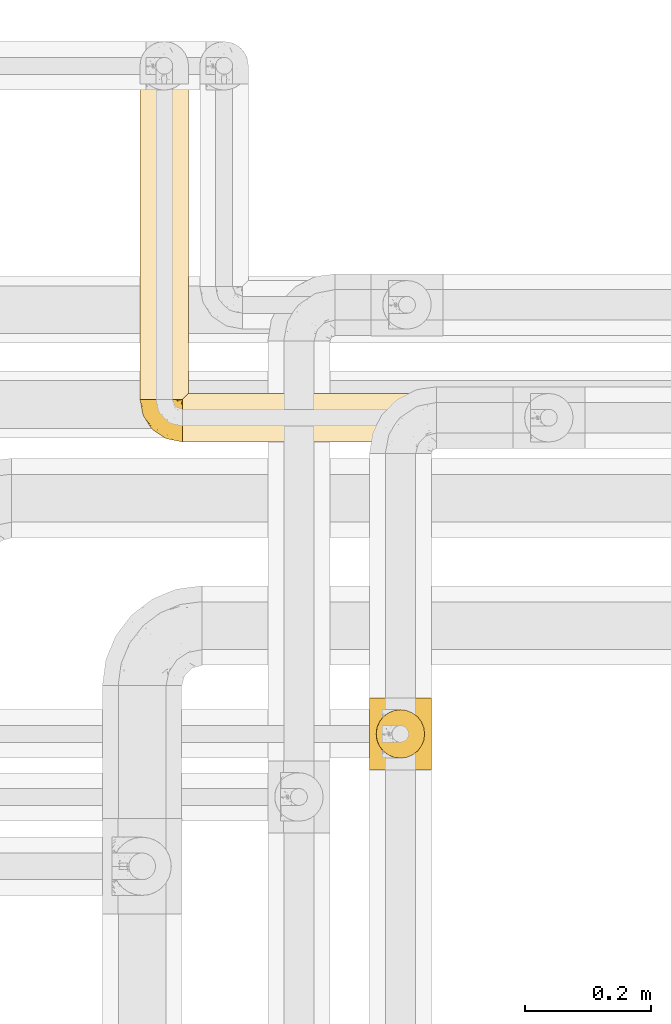
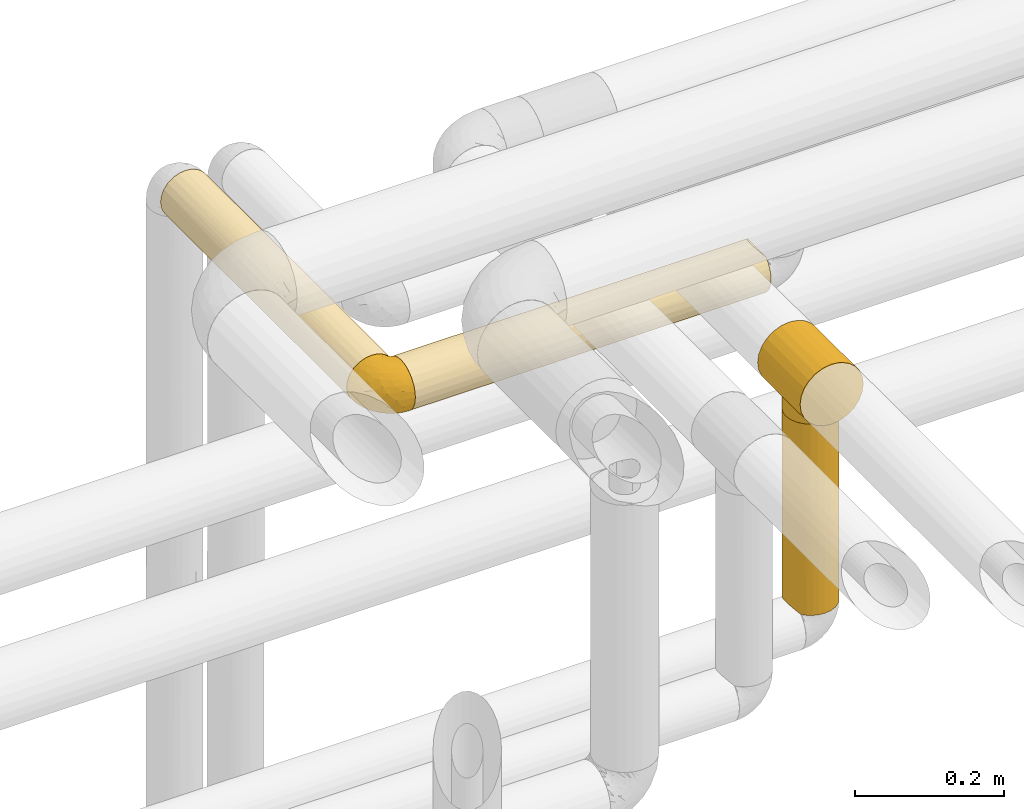
# One storey, part 364 of 827: 5 coverings.
"""IFC2X3 building model written with IfcOpenShell, lengths in millimetres."""

from ifc_helpers import new_model, entity, si_unit, converted_unit, derived_unit, direction, frame, origin, place, context, subcontext, project, spatial, faceted_brep, element, save


model = new_model("IFC2X3")

# Units and contexts
model_context = context("Model", 3, precision=0.01, world=origin(), true_north=direction((6.12303176911189e-17, 1.0)))
body_context = subcontext(model_context, "Body", "Model", "MODEL_VIEW")
ifc_project = project(units=[si_unit("LENGTHUNIT", "METRE", prefix="MILLI"), si_unit("AREAUNIT", "SQUARE_METRE"), si_unit("VOLUMEUNIT", "CUBIC_METRE"), converted_unit("PLANEANGLEUNIT", "DEGREE", entity("IfcRatioMeasure", 0.0174532925199433), si_unit("PLANEANGLEUNIT", "RADIAN"), dimensions=[0, 0, 0, 0, 0, 0, 0]), si_unit("MASSUNIT", "GRAM", prefix="KILO"), derived_unit("MASSDENSITYUNIT", [(si_unit("MASSUNIT", "GRAM", prefix="KILO"), 1), (si_unit("LENGTHUNIT", "METRE"), -3)]), derived_unit("MOMENTOFINERTIAUNIT", [(si_unit("LENGTHUNIT", "METRE"), 4)]), si_unit("TIMEUNIT", "SECOND"), si_unit("FREQUENCYUNIT", "HERTZ"), si_unit("THERMODYNAMICTEMPERATUREUNIT", "DEGREE_CELSIUS"), derived_unit("THERMALTRANSMITTANCEUNIT", [(si_unit("MASSUNIT", "GRAM", prefix="KILO"), 1), (si_unit("THERMODYNAMICTEMPERATUREUNIT", "KELVIN"), -1), (si_unit("TIMEUNIT", "SECOND"), -3)]), derived_unit("VOLUMETRICFLOWRATEUNIT", [(si_unit("LENGTHUNIT", "METRE"), 3), (si_unit("TIMEUNIT", "SECOND"), -1)]), derived_unit("MASSFLOWRATEUNIT", [(si_unit("MASSUNIT", "GRAM", prefix="KILO"), 1), (si_unit("TIMEUNIT", "SECOND"), -1)]), derived_unit("ROTATIONALFREQUENCYUNIT", [(si_unit("TIMEUNIT", "SECOND"), -1)]), si_unit("ELECTRICCURRENTUNIT", "AMPERE"), si_unit("ELECTRICVOLTAGEUNIT", "VOLT"), si_unit("POWERUNIT", "WATT"), si_unit("FORCEUNIT", "NEWTON", prefix="KILO"), si_unit("ILLUMINANCEUNIT", "LUX"), si_unit("LUMINOUSFLUXUNIT", "LUMEN"), si_unit("LUMINOUSINTENSITYUNIT", "CANDELA"), derived_unit("USERDEFINED", [(si_unit("MASSUNIT", "GRAM", prefix="KILO"), -1), (si_unit("LENGTHUNIT", "METRE"), -2), (si_unit("TIMEUNIT", "SECOND"), 3), (si_unit("LUMINOUSFLUXUNIT", "LUMEN"), 1)]), derived_unit("LINEARVELOCITYUNIT", [(si_unit("LENGTHUNIT", "METRE"), 1), (si_unit("TIMEUNIT", "SECOND"), -1)]), si_unit("PRESSUREUNIT", "PASCAL"), derived_unit("USERDEFINED", [(si_unit("LENGTHUNIT", "METRE"), -2), (si_unit("MASSUNIT", "GRAM", prefix="KILO"), 1), (si_unit("TIMEUNIT", "SECOND"), -2)]), derived_unit("LINEARFORCEUNIT", [(si_unit("MASSUNIT", "GRAM", prefix="KILO"), 1), (si_unit("LENGTHUNIT", "METRE"), 1), (si_unit("TIMEUNIT", "SECOND"), -2), (si_unit("LENGTHUNIT", "METRE"), -1)]), derived_unit("PLANARFORCEUNIT", [(si_unit("MASSUNIT", "GRAM", prefix="KILO"), 1), (si_unit("LENGTHUNIT", "METRE"), 1), (si_unit("TIMEUNIT", "SECOND"), -2), (si_unit("LENGTHUNIT", "METRE"), -2)])], contexts=[model_context])

# Site, building, storey
site_placement = place(None, origin())
site = spatial("IfcSite", under=ifc_project, at=site_placement, CompositionType="ELEMENT")
building_placement = place(site_placement, origin())
building = spatial("IfcBuilding", under=site, at=building_placement, CompositionType="ELEMENT")
storey_placement = place(building_placement, frame((0.0, 0.0, 28200.0)))
storey = spatial("IfcBuildingStorey", under=building, at=storey_placement, Name="08", CompositionType="ELEMENT", Elevation=28200.0)

# Coverings
covering_1_placement = place(storey_placement, frame((36215.03, 18963.91, 3160.0)))
element("IfcCovering", 1, at=covering_1_placement, inside=storey, Name=":ADSK_", ObjectType=":ADSK_", PredefinedType="INSULATION", context=body_context, shape_type="Brep", body=[
    faceted_brep([(20.8, 501.6, 73.25), (30.06, 501.6, 77.09), (40.0, 501.6, 78.4), (49.93, 501.6, 77.09), (59.2, 501.6, 73.25), (67.15, 501.6, 67.15), (73.25, 501.6, 59.2), (77.09, 501.6, 49.93), (78.4, 501.6, 40.0), (77.51, 501.6, 31.79), (74.9, 501.6, 23.98), (70.68, 501.6, 16.91), (65.05, 501.6, 10.9), (14.94, 501.6, 10.9), (9.31, 501.6, 16.91), (5.09, 501.6, 23.98), (2.48, 501.6, 31.79), (1.6, 501.6, 40.0), (2.9, 501.6, 49.93), (6.74, 501.6, 59.2), (12.84, 501.6, 67.15), (40.0, 1.6, 78.4), (30.06, 1.6, 77.09), (20.8, 1.6, 73.25), (12.84, 1.6, 67.15), (6.74, 1.6, 59.2), (2.9, 1.6, 49.93), (1.6, 1.6, 40.0), (2.9, 1.6, 30.06), (6.74, 1.6, 20.8), (12.84, 1.6, 12.84), (20.8, 1.6, 6.74), (30.06, 1.6, 2.9), (40.0, 1.6, 1.6), (48.2, 1.6, 2.48), (56.01, 1.6, 5.09), (63.08, 1.6, 9.31), (69.1, 1.6, 14.94), (69.1, 1.6, 65.05), (63.08, 1.6, 70.68), (56.01, 1.6, 74.9), (48.2, 1.6, 77.51), (77.02, 249.2, 29.81), (71.11, 243.29, 17.49), (73.07, 5.57, 20.48), (76.0, 8.5, 26.63), (74.63, 188.38, 23.41), (78.4, 227.27, 40.0), (77.79, 10.29, 33.21), (78.4, 10.9, 40.0), (50.18, 254.0, 2.97), (46.78, 492.91, 2.2), (53.36, 494.7, 4.0), (40.0, 275.93, 1.6), (62.51, 259.91, 8.88), (56.58, 314.82, 5.36), (40.0, 492.3, 1.6), (59.51, 497.63, 6.92), (29.81, 257.47, 2.97), (17.48, 247.3, 8.89), (23.43, 190.65, 5.35), (9.53, 230.73, 16.62), (33.21, 492.91, 2.2), (26.63, 494.7, 4.0), (20.48, 497.63, 6.92), (3.58, 261.19, 27.82), (1.6, 285.23, 40.0), (2.35, 293.81, 47.55), (4.52, 251.6, 54.69), (32.65, 290.19, 77.69), (25.3, 251.6, 75.47), (9.53, 251.6, 63.37), (16.62, 251.6, 70.46), (40.0, 217.97, 78.4), (52.17, 242.01, 76.41), (63.37, 272.47, 70.46), (77.02, 245.73, 50.18), (77.79, 10.29, 46.78), (74.64, 312.55, 56.56), (71.1, 255.89, 62.51), (76.0, 8.5, 53.36), (73.07, 5.57, 59.51)], [[[0, 1, 2, 3, 4, 5, 6, 7, 8, 9, 10, 11, 12, 13, 14, 15, 16, 17, 18, 19, 20]], [[21, 22, 23, 24, 25, 26, 27, 28, 29, 30, 31, 32, 33, 34, 35, 36, 37, 38, 39, 40, 41]], [[42, 10, 9]], [[10, 43, 11]], [[44, 37, 43]], [[42, 45, 46]], [[8, 47, 9]], [[43, 46, 44]], [[47, 42, 9]], [[47, 48, 42]], [[49, 48, 47]], [[50, 51, 52]], [[53, 50, 34]], [[43, 54, 12]], [[46, 10, 42]], [[50, 52, 55]], [[12, 11, 43]], [[55, 35, 50]], [[37, 36, 54]], [[35, 55, 54]], [[53, 56, 51]], [[35, 54, 36]], [[57, 12, 54]], [[42, 48, 45]], [[50, 35, 34]], [[53, 51, 50]], [[33, 53, 34]], [[55, 57, 54]], [[10, 46, 43]], [[57, 55, 52]], [[37, 54, 43]], [[44, 46, 45]], [[33, 58, 53]], [[58, 33, 32]], [[31, 59, 60]], [[59, 30, 61]], [[62, 58, 63]], [[62, 56, 53]], [[60, 63, 58]], [[64, 63, 60]], [[31, 30, 59]], [[59, 13, 64]], [[53, 58, 62]], [[61, 30, 29]], [[32, 60, 58]], [[29, 28, 65]], [[61, 14, 13]], [[64, 60, 59]], [[66, 17, 16]], [[65, 16, 15]], [[15, 61, 65]], [[66, 65, 28]], [[15, 14, 61]], [[66, 16, 65]], [[27, 66, 28]], [[65, 61, 29]], [[13, 59, 61]], [[32, 31, 60]], [[67, 26, 68]], [[22, 69, 70]], [[67, 17, 66, 27]], [[68, 26, 25]], [[67, 27, 26]], [[18, 68, 19]], [[68, 18, 67]], [[71, 20, 19]], [[71, 68, 25]], [[72, 71, 24]], [[2, 69, 73]], [[70, 23, 22]], [[22, 21, 73]], [[69, 1, 70]], [[2, 1, 69]], [[72, 0, 20]], [[70, 72, 23]], [[22, 73, 69]], [[70, 0, 72]], [[71, 72, 20]], [[24, 71, 25]], [[0, 70, 1]], [[23, 72, 24]], [[17, 67, 18]], [[68, 71, 19]], [[73, 41, 74]], [[40, 39, 75]], [[75, 74, 40]], [[47, 76, 77]], [[41, 73, 21]], [[74, 41, 40]], [[74, 4, 3]], [[75, 5, 4]], [[7, 6, 78]], [[79, 75, 38]], [[78, 80, 76]], [[79, 5, 75]], [[77, 76, 80]], [[6, 5, 79]], [[77, 49, 47]], [[78, 81, 80]], [[73, 74, 3]], [[78, 6, 79]], [[75, 39, 38]], [[8, 7, 76]], [[76, 47, 8]], [[74, 75, 4]], [[81, 78, 79]], [[81, 79, 38]], [[7, 78, 76]], [[2, 73, 3]], [[52, 51, 56, 62, 63, 64, 13, 12, 57]], [[37, 44, 45, 48, 49, 77, 80, 81, 38]]]),
])
covering_2_placement = place(storey_placement, frame((36282.53, 18896.41, 3160.0)))
element("IfcCovering", 2, at=covering_2_placement, inside=storey, Name=":ADSK_", ObjectType=":ADSK_", PredefinedType="INSULATION", context=body_context, shape_type="Brep", body=[
    faceted_brep([(1.6, 20.8, 6.74), (1.6, 12.84, 12.84), (1.6, 6.74, 20.8), (1.6, 2.9, 30.06), (1.6, 1.6, 40.0), (1.6, 2.9, 49.93), (1.6, 6.74, 59.2), (1.6, 12.84, 67.15), (1.6, 20.8, 73.25), (1.6, 30.06, 77.09), (1.6, 40.0, 78.4), (1.6, 48.2, 77.51), (1.6, 56.01, 74.9), (1.6, 63.08, 70.68), (1.6, 69.1, 65.05), (1.6, 69.1, 14.94), (1.6, 63.08, 9.31), (1.6, 56.01, 5.09), (1.6, 48.2, 2.48), (1.6, 40.0, 1.6), (1.6, 30.06, 2.9), (553.4, 2.9, 30.06), (553.4, 6.74, 20.8), (553.4, 12.84, 12.84), (553.4, 20.8, 6.74), (553.4, 30.06, 2.9), (553.4, 40.0, 1.6), (553.4, 49.93, 2.9), (553.4, 59.2, 6.74), (553.4, 67.15, 12.84), (553.4, 73.25, 20.8), (553.4, 77.09, 30.06), (553.4, 78.4, 40.0), (553.4, 77.51, 48.2), (553.4, 74.9, 56.01), (553.4, 70.68, 63.08), (553.4, 65.05, 69.1), (553.4, 14.94, 69.1), (553.4, 9.31, 63.08), (553.4, 5.09, 56.01), (553.4, 2.48, 48.2), (553.4, 1.6, 40.0), (268.81, 52.17, 3.58), (272.56, 77.02, 29.8), (227.27, 78.4, 40.0), (10.29, 77.79, 33.21), (10.9, 78.4, 40.0), (357.32, 74.63, 23.42), (281.58, 71.09, 17.46), (296.41, 63.37, 9.53), (8.5, 76.0, 26.63), (5.57, 73.07, 20.48), (217.97, 40.0, 1.6), (209.63, 32.43, 2.35), (253.62, 25.3, 4.52), (215.59, 2.33, 32.5), (277.5, 4.52, 25.3), (277.5, 16.62, 9.53), (253.62, 9.53, 16.62), (277.5, 1.6, 40.0), (337.02, 1.6, 40.0), (286.18, 3.58, 52.17), (258.58, 9.53, 63.37), (327.72, 40.0, 78.4), (282.43, 29.8, 77.02), (544.7, 33.21, 77.79), (197.67, 23.42, 74.63), (273.41, 17.46, 71.09), (546.5, 26.63, 76.0), (544.1, 40.0, 78.4), (549.42, 20.48, 73.07), (279.27, 50.19, 77.02), (284.96, 62.52, 71.09), (549.42, 59.51, 73.07), (270.03, 71.09, 62.52), (359.39, 56.59, 74.63), (544.7, 46.78, 77.79), (275.72, 77.02, 50.19), (10.29, 77.79, 46.78), (8.5, 76.0, 53.36), (195.6, 74.63, 56.59), (546.5, 53.36, 76.0), (5.57, 73.07, 59.51)], [[[0, 1, 2, 3, 4, 5, 6, 7, 8, 9, 10, 11, 12, 13, 14, 15, 16, 17, 18, 19, 20]], [[21, 22, 23, 24, 25, 26, 27, 28, 29, 30, 31, 32, 33, 34, 35, 36, 37, 38, 39, 40, 41]], [[42, 18, 17]], [[32, 43, 44]], [[43, 32, 31]], [[45, 46, 44]], [[31, 30, 47]], [[30, 48, 47]], [[48, 29, 49]], [[45, 43, 50]], [[44, 43, 45]], [[47, 50, 43]], [[51, 50, 47]], [[30, 29, 48]], [[48, 15, 51]], [[26, 52, 27]], [[49, 29, 28]], [[28, 27, 42]], [[52, 19, 18]], [[42, 49, 28]], [[17, 49, 42]], [[51, 47, 48]], [[17, 16, 49]], [[52, 18, 42]], [[49, 16, 15]], [[31, 47, 43]], [[15, 48, 49]], [[52, 42, 27]], [[53, 25, 54]], [[21, 55, 56]], [[53, 19, 52, 26]], [[54, 57, 0]], [[57, 54, 24]], [[53, 26, 25]], [[23, 57, 24]], [[57, 1, 0]], [[0, 20, 54]], [[22, 56, 58]], [[4, 55, 59]], [[56, 22, 21]], [[56, 2, 58]], [[23, 58, 57]], [[21, 41, 60, 59]], [[1, 57, 58]], [[22, 58, 23]], [[53, 54, 20]], [[2, 1, 58]], [[56, 55, 3]], [[2, 56, 3]], [[24, 54, 25]], [[59, 55, 21]], [[19, 53, 20]], [[55, 4, 3]], [[60, 40, 61]], [[39, 38, 62]], [[62, 61, 39]], [[63, 64, 65]], [[40, 60, 41]], [[61, 40, 39]], [[61, 6, 5]], [[62, 7, 6]], [[9, 8, 66]], [[67, 62, 37]], [[66, 68, 64]], [[67, 7, 62]], [[65, 64, 68]], [[8, 7, 67]], [[65, 69, 63]], [[66, 70, 68]], [[60, 61, 5]], [[66, 8, 67]], [[62, 38, 37]], [[10, 9, 64]], [[64, 63, 10]], [[61, 62, 6]], [[70, 66, 67]], [[70, 67, 37]], [[9, 66, 64]], [[5, 4, 59, 60]], [[71, 12, 11]], [[12, 72, 13]], [[73, 36, 72]], [[34, 74, 35]], [[10, 63, 11]], [[72, 75, 73]], [[63, 76, 71]], [[69, 76, 63]], [[77, 78, 79]], [[77, 79, 80]], [[63, 71, 11]], [[75, 12, 71]], [[71, 81, 75]], [[14, 13, 72]], [[80, 34, 77]], [[36, 35, 74]], [[82, 80, 79]], [[34, 80, 74]], [[44, 46, 78]], [[72, 74, 14]], [[82, 14, 74]], [[71, 76, 81]], [[77, 34, 33]], [[44, 78, 77]], [[32, 44, 33]], [[80, 82, 74]], [[73, 75, 81]], [[12, 75, 72]], [[36, 74, 72]], [[44, 77, 33]], [[14, 82, 79, 78, 46, 45, 50, 51, 15]], [[69, 65, 68, 70, 37, 36, 73, 81, 76]]]),
])
covering_3_placement = place(storey_placement, frame((36214.98, 18896.36, 3159.95)))
element("IfcCovering", 3, at=covering_3_placement, inside=storey, Name=":ADSK_", ObjectType=":ADSK_", PredefinedType="INSULATION", context=body_context, shape_type="Brep", body=[
    faceted_brep([(69.15, 23.36, 74.68), (69.15, 16.07, 70.1), (69.15, 9.98, 64.01), (69.15, 5.4, 56.72), (69.15, 2.56, 48.6), (69.15, 1.6, 40.05), (69.15, 2.56, 31.49), (69.15, 5.41, 23.36), (69.15, 9.99, 16.07), (69.15, 16.08, 9.98), (69.15, 23.37, 5.4), (69.15, 31.49, 2.56), (69.15, 40.05, 1.6), (69.15, 48.15, 2.46), (69.15, 55.88, 5.01), (69.15, 62.9, 9.13), (69.15, 68.89, 14.62), (69.15, 68.89, 16.82), (69.15, 68.89, 18.56), (69.15, 68.89, 20.52), (69.15, 68.89, 22.49), (69.15, 68.89, 24.46), (69.15, 68.89, 26.42), (69.15, 68.89, 28.39), (69.15, 68.89, 30.36), (69.15, 68.89, 32.55), (69.15, 68.89, 34.75), (69.15, 68.89, 36.94), (69.15, 68.89, 39.13), (69.15, 68.89, 41.33), (69.15, 68.89, 43.52), (69.15, 68.89, 45.72), (69.15, 68.89, 47.91), (69.15, 68.89, 50.11), (69.15, 68.89, 52.3), (69.15, 68.89, 54.49), (69.15, 68.89, 56.69), (69.15, 68.89, 58.88), (69.15, 68.89, 61.08), (69.15, 68.89, 63.27), (69.15, 68.89, 65.47), (69.15, 62.89, 70.97), (69.15, 55.86, 75.09), (69.15, 48.13, 77.64), (69.15, 40.05, 78.5), (69.15, 31.49, 77.53), (68.89, 69.15, 14.62), (62.89, 69.15, 9.12), (55.87, 69.15, 5.0), (48.14, 69.15, 2.46), (40.05, 69.15, 1.6), (30.09, 69.15, 2.91), (20.82, 69.15, 6.75), (12.86, 69.15, 12.86), (6.75, 69.15, 20.82), (2.91, 69.15, 30.09), (1.6, 69.15, 40.05), (2.91, 69.15, 50.0), (6.75, 69.15, 59.27), (12.86, 69.15, 67.23), (20.82, 69.15, 73.34), (30.09, 69.15, 77.19), (40.05, 69.15, 78.5), (48.14, 69.15, 77.63), (55.87, 69.15, 75.09), (62.89, 69.15, 70.97), (68.89, 69.15, 65.47), (68.89, 69.15, 63.27), (68.89, 69.15, 62.29), (68.89, 69.15, 60.7), (68.89, 69.15, 59.11), (68.89, 69.15, 57.52), (68.89, 69.15, 55.93), (68.89, 69.15, 54.34), (68.89, 69.15, 52.76), (68.89, 69.15, 51.17), (68.89, 69.15, 49.58), (68.89, 69.15, 47.99), (68.89, 69.15, 46.4), (68.89, 69.15, 44.81), (68.89, 69.15, 43.22), (68.89, 69.15, 41.63), (68.89, 69.15, 40.05), (68.89, 69.15, 38.46), (68.89, 69.15, 36.87), (68.89, 69.15, 35.28), (68.89, 69.15, 33.69), (68.89, 69.15, 32.1), (68.89, 69.15, 30.51), (68.89, 69.15, 28.92), (68.89, 69.15, 27.33), (68.89, 69.15, 25.37), (68.89, 69.15, 23.4), (68.89, 69.15, 21.21), (68.89, 69.15, 19.01), (68.89, 69.15, 16.82), (68.97, 68.96, 42.32), (68.96, 68.97, 44.02), (68.97, 68.97, 47.13), (68.97, 68.97, 48.74), (68.98, 68.95, 23.57), (68.97, 68.96, 25.13), (68.96, 68.98, 61.34), (68.96, 68.97, 22.02), (68.96, 68.97, 29.72), (68.96, 68.98, 56.73), (68.96, 68.97, 55.14), (68.96, 68.97, 37.66), (69.0, 68.94, 64.12), (68.96, 68.98, 28.13), (68.96, 68.98, 26.62), (68.97, 68.96, 31.46), (68.96, 68.97, 16.16), (68.96, 68.98, 39.16), (68.96, 68.98, 50.37), (68.97, 68.97, 17.69), (68.97, 68.96, 19.17), (68.97, 68.97, 62.78), (68.96, 68.97, 58.35), (68.96, 68.98, 45.53), (68.97, 68.96, 59.91), (68.97, 68.97, 65.47), (69.02, 68.94, 65.47), (69.08, 68.92, 65.47), (68.97, 68.97, 14.62), (68.94, 69.02, 14.62), (68.92, 69.08, 14.62), (68.96, 68.98, 20.59), (68.96, 68.97, 32.99), (68.95, 68.98, 34.48), (68.96, 68.97, 51.91), (68.92, 69.08, 65.47), (68.94, 69.02, 65.47), (68.98, 68.96, 53.48), (69.08, 68.92, 14.62), (69.02, 68.94, 14.62), (68.96, 68.97, 40.77), (68.97, 68.96, 35.97), (61.33, 67.02, 7.84), (53.1, 63.33, 3.53), (63.33, 64.61, 8.32), (49.27, 49.27, 1.6), (55.53, 51.4, 2.19), (54.6, 43.94, 1.6), (41.99, 61.87, 1.6), (57.07, 61.54, 4.57), (57.95, 57.95, 3.96), (51.56, 56.12, 2.28), (41.58, 63.4, 1.6), (61.7, 65.41, 7.69), (63.33, 53.1, 3.53), (65.0, 63.04, 8.32), (67.02, 61.33, 7.84), (61.87, 41.99, 1.6), (43.94, 54.6, 1.6), (61.21, 56.6, 4.34), (63.4, 41.58, 1.6), (33.11, 13.72, 29.63), (52.82, 5.82, 27.34), (43.3, 6.74, 40.05), (33.73, 58.82, 2.39), (36.52, 51.58, 2.43), (24.87, 42.09, 9.07), (14.17, 46.12, 16.64), (18.43, 55.56, 9.54), (28.67, 52.38, 4.52), (26.0, 61.54, 4.52), (49.25, 23.76, 7.49), (59.72, 20.5, 7.49), (55.1, 14.64, 12.85), (44.72, 41.77, 2.35), (34.15, 16.28, 22.66), (5.25, 49.4, 32.9), (6.75, 52.34, 25.33), (55.54, 4.3, 40.05), (10.47, 58.67, 16.64), (25.49, 25.26, 19.99), (35.53, 20.17, 16.37), (48.22, 34.7, 3.26), (58.71, 28.67, 3.75), (57.42, 8.62, 19.58), (34.84, 33.37, 7.5), (36.87, 41.35, 4.04), (45.01, 17.15, 13.94), (44.4, 12.68, 19.58), (23.96, 21.47, 28.21), (11.2, 41.11, 24.75), (10.56, 37.53, 31.42), (16.81, 30.64, 26.2), (17.38, 26.66, 33.36), (21.38, 21.38, 40.05), (32.34, 14.06, 40.05), (4.3, 55.54, 40.05), (20.65, 35.17, 16.14), (29.66, 29.04, 12.85), (39.6, 24.34, 10.47), (42.55, 29.33, 6.49), (6.74, 43.3, 40.05), (14.06, 32.34, 40.05), (26.84, 57.75, 75.57), (5.28, 49.41, 47.37), (18.52, 27.85, 52.91), (33.13, 13.7, 50.46), (55.1, 14.63, 67.23), (57.43, 8.61, 60.5), (20.72, 48.85, 70.55), (11.46, 54.13, 63.45), (17.69, 37.84, 62.61), (49.26, 23.75, 72.6), (59.73, 20.49, 72.6), (58.71, 28.66, 76.34), (29.72, 20.83, 59.34), (35.35, 55.15, 77.76), (43.94, 54.6, 78.5), (41.99, 61.87, 78.5), (63.4, 41.58, 78.5), (4.93, 57.58, 53.16), (17.46, 59.91, 70.55), (10.94, 36.94, 48.88), (8.92, 45.72, 54.76), (52.83, 5.82, 52.74), (29.34, 37.91, 71.93), (30.26, 50.18, 75.79), (44.4, 12.67, 60.5), (39.06, 49.29, 77.86), (43.06, 42.64, 77.64), (54.6, 43.94, 78.5), (49.27, 49.27, 78.5), (42.69, 19.45, 67.23), (48.2, 34.7, 76.82), (61.87, 41.99, 78.5), (33.44, 62.29, 77.8), (29.67, 29.01, 67.23), (38.5, 31.47, 73.2), (23.35, 37.18, 67.66), (34.97, 43.45, 75.99), (53.1, 63.33, 76.57), (59.68, 67.23, 73.21), (62.19, 66.07, 71.93), (64.11, 65.22, 71.07), (57.97, 61.99, 75.09), (57.95, 57.95, 76.13), (63.33, 53.09, 76.57), (51.77, 56.84, 77.69), (67.02, 61.33, 72.26), (64.98, 63.06, 71.77), (55.53, 51.41, 77.9), (61.22, 56.61, 75.75)], [[[0, 1, 2, 3, 4, 5, 6, 7, 8, 9, 10, 11, 12, 13, 14, 15, 16, 17, 18, 19, 20, 21, 22, 23, 24, 25, 26, 27, 28, 29, 30, 31, 32, 33, 34, 35, 36, 37, 38, 39, 40, 41, 42, 43, 44, 45]], [[46, 47, 48, 49, 50, 51, 52, 53, 54, 55, 56, 57, 58, 59, 60, 61, 62, 63, 64, 65, 66, 67, 68, 69, 70, 71, 72, 73, 74, 75, 76, 77, 78, 79, 80, 81, 82, 83, 84, 85, 86, 87, 88, 89, 90, 91, 92, 93, 94, 95]], [[96, 97, 30]], [[98, 77, 99]], [[100, 101, 21]], [[69, 68, 102]], [[20, 19, 103]], [[24, 23, 104]], [[20, 103, 100]], [[72, 105, 106]], [[84, 83, 107]], [[89, 88, 104]], [[108, 67, 66]], [[109, 110, 90]], [[111, 25, 24]], [[112, 17, 16]], [[82, 113, 83]], [[109, 23, 22]], [[114, 76, 75]], [[105, 36, 106]], [[104, 111, 24]], [[18, 115, 116]], [[97, 96, 80]], [[67, 108, 117]], [[105, 71, 118]], [[31, 97, 119]], [[102, 120, 69]], [[108, 121, 122, 123, 40]], [[112, 95, 115]], [[17, 115, 18]], [[94, 116, 115]], [[117, 68, 67]], [[38, 117, 39]], [[112, 124, 125, 126, 46]], [[17, 112, 115]], [[70, 120, 118]], [[39, 117, 108]], [[120, 38, 37]], [[120, 37, 118]], [[120, 70, 69]], [[116, 94, 127]], [[128, 86, 129]], [[117, 38, 102]], [[74, 130, 75]], [[99, 33, 32]], [[115, 95, 94]], [[39, 108, 40]], [[108, 66, 131, 132, 121]], [[105, 72, 71]], [[118, 37, 36]], [[71, 70, 118]], [[35, 106, 36]], [[36, 105, 118]], [[35, 133, 106]], [[74, 73, 133]], [[106, 133, 73]], [[99, 114, 33]], [[133, 35, 34]], [[73, 72, 106]], [[95, 112, 46]], [[112, 16, 134, 135, 124]], [[130, 114, 75]], [[99, 76, 114]], [[114, 130, 33]], [[34, 33, 130]], [[78, 77, 98]], [[98, 119, 78]], [[130, 133, 34]], [[133, 130, 74]], [[79, 97, 80]], [[98, 99, 32]], [[98, 32, 31]], [[77, 76, 99]], [[97, 79, 119]], [[136, 96, 29]], [[30, 97, 31]], [[136, 29, 28]], [[81, 80, 96]], [[29, 96, 30]], [[31, 119, 98]], [[119, 79, 78]], [[96, 136, 81]], [[82, 81, 136]], [[113, 107, 83]], [[84, 107, 137]], [[107, 27, 137]], [[113, 28, 107]], [[27, 107, 28]], [[85, 84, 137]], [[137, 27, 26]], [[113, 136, 28]], [[136, 113, 82]], [[109, 89, 104]], [[86, 85, 129]], [[89, 109, 90]], [[111, 87, 128]], [[26, 129, 137]], [[88, 111, 104]], [[25, 111, 128]], [[22, 110, 109]], [[23, 109, 104]], [[110, 91, 90]], [[100, 92, 101]], [[110, 22, 101]], [[91, 110, 101]], [[116, 19, 18]], [[111, 88, 87]], [[127, 103, 19]], [[25, 128, 26]], [[86, 128, 87]], [[128, 129, 26]], [[137, 129, 85]], [[120, 102, 38]], [[117, 102, 68]], [[91, 101, 92]], [[21, 101, 22]], [[93, 92, 103]], [[100, 21, 20]], [[100, 103, 92]], [[127, 93, 103]], [[93, 127, 94]], [[116, 127, 19]], [[126, 138, 47]], [[48, 138, 139]], [[140, 125, 124]], [[141, 142, 143]], [[144, 49, 139]], [[145, 140, 146]], [[48, 139, 49]], [[139, 145, 147]], [[49, 144, 148, 50]], [[126, 125, 149]], [[14, 13, 150]], [[151, 146, 140]], [[149, 140, 145]], [[152, 151, 135]], [[152, 14, 150]], [[16, 15, 134]], [[13, 153, 150]], [[124, 151, 140]], [[141, 147, 142]], [[14, 152, 15]], [[15, 152, 134]], [[47, 46, 126]], [[139, 154, 144]], [[138, 48, 47]], [[125, 140, 149]], [[135, 134, 152]], [[146, 155, 142]], [[145, 146, 147]], [[149, 139, 138]], [[147, 141, 154]], [[147, 146, 142]], [[139, 147, 154]], [[139, 149, 145]], [[149, 138, 126]], [[155, 146, 151]], [[150, 143, 142]], [[152, 155, 151]], [[150, 142, 155]], [[13, 12, 156, 153]], [[153, 143, 150]], [[152, 150, 155]], [[151, 124, 135]], [[157, 158, 159]], [[160, 154, 161]], [[162, 163, 164]], [[165, 166, 160]], [[167, 168, 169]], [[141, 170, 161]], [[156, 12, 11]], [[158, 157, 171]], [[172, 55, 173]], [[158, 6, 174]], [[175, 54, 53]], [[52, 166, 164]], [[52, 164, 53]], [[54, 175, 173]], [[166, 52, 51]], [[176, 177, 171]], [[178, 143, 179]], [[156, 11, 179]], [[8, 7, 180]], [[169, 9, 8]], [[179, 143, 153, 156]], [[179, 11, 10]], [[168, 179, 10]], [[181, 162, 182]], [[179, 167, 178]], [[183, 184, 177]], [[183, 169, 184]], [[176, 171, 185]], [[172, 186, 187]], [[158, 7, 6]], [[159, 158, 174]], [[184, 180, 158]], [[54, 173, 55]], [[180, 169, 8]], [[188, 189, 187]], [[9, 168, 10]], [[186, 188, 187]], [[190, 157, 159, 191]], [[55, 172, 192]], [[176, 193, 194]], [[161, 170, 182]], [[162, 164, 165]], [[175, 164, 163]], [[51, 50, 148]], [[167, 195, 196]], [[178, 182, 170]], [[6, 5, 174]], [[158, 180, 7]], [[169, 180, 184]], [[169, 168, 9]], [[179, 168, 167]], [[182, 162, 165]], [[162, 194, 193]], [[161, 165, 160]], [[195, 181, 196]], [[192, 172, 197]], [[192, 56, 55]], [[189, 190, 198]], [[198, 197, 187]], [[172, 187, 197]], [[185, 189, 188]], [[198, 187, 189]], [[186, 172, 173]], [[173, 163, 186]], [[193, 186, 163]], [[176, 185, 188]], [[185, 157, 190]], [[188, 186, 193]], [[177, 176, 194]], [[188, 193, 176]], [[162, 193, 163]], [[195, 177, 194]], [[171, 177, 184]], [[181, 195, 194]], [[183, 167, 169]], [[162, 181, 194]], [[196, 182, 178]], [[158, 171, 184]], [[171, 157, 185]], [[177, 195, 183]], [[167, 183, 195]], [[182, 196, 181]], [[178, 170, 143]], [[178, 167, 196]], [[164, 175, 53]], [[173, 175, 163]], [[160, 51, 148]], [[164, 166, 165]], [[51, 160, 166]], [[160, 148, 144, 154]], [[141, 161, 154]], [[182, 165, 161]], [[190, 189, 185]], [[143, 170, 141]], [[60, 199, 61]], [[197, 200, 192]], [[201, 190, 202]], [[200, 57, 192]], [[203, 204, 2]], [[205, 206, 207]], [[208, 209, 210]], [[211, 207, 201]], [[212, 213, 214]], [[45, 215, 210]], [[216, 206, 58]], [[45, 44, 215]], [[59, 217, 60]], [[60, 217, 199]], [[0, 45, 210]], [[218, 201, 219]], [[202, 159, 220]], [[205, 221, 222]], [[223, 204, 203]], [[1, 203, 2]], [[57, 200, 216]], [[220, 3, 204]], [[220, 174, 4]], [[1, 0, 209]], [[212, 224, 213]], [[225, 226, 227]], [[228, 223, 203]], [[208, 210, 229]], [[210, 226, 229]], [[3, 220, 4]], [[58, 206, 59]], [[209, 203, 1]], [[202, 220, 223]], [[228, 203, 208]], [[202, 211, 201]], [[3, 2, 204]], [[202, 190, 191, 159]], [[210, 215, 230, 226]], [[199, 212, 231]], [[232, 233, 221]], [[233, 208, 229]], [[207, 206, 219]], [[217, 206, 205]], [[227, 224, 225]], [[233, 232, 228]], [[201, 207, 219]], [[234, 232, 221]], [[218, 219, 200]], [[202, 223, 211]], [[174, 220, 159]], [[174, 5, 4]], [[61, 231, 62]], [[220, 204, 223]], [[210, 209, 0]], [[203, 209, 208]], [[225, 233, 229]], [[224, 227, 213]], [[221, 233, 235]], [[57, 56, 192]], [[198, 218, 197]], [[200, 219, 216]], [[201, 198, 190]], [[197, 218, 200]], [[198, 201, 218]], [[206, 216, 219]], [[58, 57, 216]], [[231, 212, 214]], [[222, 212, 199]], [[228, 211, 223]], [[207, 211, 232]], [[62, 231, 214]], [[199, 231, 61]], [[233, 228, 208]], [[211, 228, 232]], [[222, 221, 235]], [[234, 205, 207]], [[206, 217, 59]], [[199, 217, 205]], [[205, 222, 199]], [[224, 222, 235]], [[222, 224, 212]], [[224, 235, 225]], [[233, 225, 235]], [[226, 225, 229]], [[205, 234, 221]], [[207, 232, 234]], [[63, 214, 236]], [[214, 213, 236]], [[214, 63, 62]], [[237, 236, 238]], [[238, 132, 131]], [[236, 237, 64]], [[239, 240, 241]], [[63, 236, 64]], [[131, 66, 65]], [[237, 131, 65]], [[242, 230, 43]], [[237, 65, 64]], [[239, 121, 132]], [[42, 242, 43]], [[241, 240, 243]], [[41, 123, 244]], [[43, 230, 215, 44]], [[244, 122, 245]], [[227, 246, 243]], [[241, 247, 245]], [[121, 239, 245]], [[41, 40, 123]], [[132, 238, 239]], [[244, 42, 41]], [[131, 237, 238]], [[240, 239, 238]], [[245, 239, 241]], [[247, 241, 246]], [[247, 244, 245]], [[238, 236, 240]], [[243, 236, 213]], [[236, 243, 240]], [[227, 226, 246]], [[243, 213, 227]], [[242, 246, 226]], [[243, 246, 241]], [[246, 242, 247]], [[244, 247, 242]], [[242, 226, 230]], [[42, 244, 242]], [[122, 244, 123]], [[122, 121, 245]]]),
])
covering_4_placement = place(storey_placement, frame((36589.65, 18394.91, 3027.67)))
element("IfcCovering", 4, at=covering_4_placement, inside=storey, Name=":ADSK_", ObjectType=":ADSK_", PredefinedType="INSULATION", context=body_context, shape_type="Brep", body=[
    faceted_brep([(16.91, 9.31, 1.6), (10.9, 14.94, 1.6), (10.9, 65.05, 1.6), (16.91, 70.68, 1.6), (23.98, 74.9, 1.6), (31.79, 77.51, 1.6), (40.0, 78.4, 1.6), (49.93, 77.09, 1.6), (59.2, 73.25, 1.6), (67.15, 67.15, 1.6), (73.25, 59.2, 1.6), (77.09, 49.93, 1.6), (78.4, 40.0, 1.6), (77.09, 30.06, 1.6), (73.25, 20.8, 1.6), (67.15, 12.84, 1.6), (59.2, 6.74, 1.6), (49.93, 2.9, 1.6), (40.0, 1.6, 1.6), (31.79, 2.48, 1.6), (23.98, 5.09, 1.6), (6.74, 20.8, 315.22), (12.84, 12.84, 315.22), (20.8, 6.74, 315.22), (30.06, 2.9, 315.22), (40.0, 1.6, 315.22), (49.93, 2.9, 315.22), (59.2, 6.74, 315.22), (67.15, 12.84, 315.22), (73.25, 20.8, 315.22), (77.09, 30.06, 315.22), (78.4, 40.0, 315.22), (77.09, 49.93, 315.22), (73.25, 59.2, 315.22), (67.15, 67.15, 315.22), (59.2, 73.25, 315.22), (49.93, 77.09, 315.22), (40.0, 78.4, 315.22), (30.06, 77.09, 315.22), (20.8, 73.25, 315.22), (12.84, 67.15, 315.22), (6.74, 59.2, 315.22), (2.9, 49.93, 315.22), (1.6, 40.0, 315.22), (2.9, 30.06, 315.22), (4.0, 26.63, 8.5), (2.2, 33.21, 10.29), (1.6, 40.0, 10.9), (6.92, 20.48, 5.57), (2.2, 46.78, 10.29), (4.0, 53.36, 8.5), (6.92, 59.51, 5.57)], [[[0, 1, 2, 3, 4, 5, 6, 7, 8, 9, 10, 11, 12, 13, 14, 15, 16, 17, 18, 19, 20]], [[21, 22, 23, 24, 25, 26, 27, 28, 29, 30, 31, 32, 33, 34, 35, 36, 37, 38, 39, 40, 41, 42, 43, 44]], [[25, 24, 19]], [[24, 23, 20]], [[0, 23, 22]], [[19, 18, 25]], [[20, 19, 24]], [[23, 0, 20]], [[22, 1, 0]], [[45, 21, 44]], [[44, 43, 46]], [[47, 46, 43]], [[48, 1, 21]], [[46, 45, 44]], [[48, 21, 45]], [[21, 1, 22]], [[49, 47, 43]], [[49, 43, 42]], [[50, 42, 41]], [[50, 49, 42]], [[2, 51, 41]], [[50, 41, 51]], [[41, 40, 2]], [[3, 40, 39]], [[4, 39, 38]], [[5, 38, 37]], [[3, 39, 4]], [[4, 38, 5]], [[37, 6, 5]], [[40, 3, 2]], [[7, 6, 37, 36]], [[8, 7, 36, 35]], [[35, 34, 9, 8]], [[11, 10, 33, 32]], [[12, 11, 32, 31]], [[34, 33, 10, 9]], [[13, 12, 31, 30]], [[14, 13, 30, 29]], [[29, 28, 15, 14]], [[17, 16, 27, 26]], [[18, 17, 26, 25]], [[28, 27, 16, 15]], [[47, 49, 50, 51, 2, 1, 48, 45, 46]]]),
])
covering_5_placement = place(storey_placement, frame((36578.9, 18377.91, 3342.89)))
element("IfcCovering", 5, at=covering_5_placement, inside=storey, Name=":ADSK_", ObjectType=":ADSK_", PredefinedType="INSULATION", context=body_context, shape_type="Brep", body=[
    faceted_brep([(26.17, 114.0, 99.57), (38.02, 114.0, 104.48), (50.75, 114.0, 106.15), (63.47, 114.0, 104.48), (75.32, 114.0, 99.57), (85.5, 114.0, 91.75), (93.31, 114.0, 81.58), (98.22, 114.0, 69.72), (99.9, 114.0, 57.0), (98.22, 114.0, 44.28), (93.31, 114.0, 32.43), (85.5, 114.0, 22.25), (80.41, 114.0, 18.34), (75.32, 114.0, 14.43), (69.39, 114.0, 11.98), (63.47, 114.0, 9.52), (60.29, 114.0, 9.11), (57.11, 114.0, 8.69), (53.93, 114.0, 8.27), (50.75, 114.0, 7.85), (47.57, 114.0, 8.27), (44.38, 114.0, 8.69), (41.2, 114.0, 9.11), (38.02, 114.0, 9.52), (32.1, 114.0, 11.98), (26.17, 114.0, 14.43), (21.08, 114.0, 18.34), (15.99, 114.0, 22.25), (8.18, 114.0, 32.43), (3.27, 114.0, 44.28), (1.6, 114.0, 57.0), (3.27, 114.0, 69.72), (8.18, 114.0, 81.58), (15.99, 114.0, 91.75), (98.22, 0.0, 69.72), (93.31, 0.0, 81.58), (85.5, 0.0, 91.75), (75.32, 0.0, 99.57), (63.47, 0.0, 104.48), (50.75, 0.0, 106.15), (38.02, 0.0, 104.48), (26.17, 0.0, 99.57), (15.99, 0.0, 91.75), (8.18, 0.0, 81.58), (3.27, 0.0, 69.72), (1.6, 0.0, 57.0), (3.27, 0.0, 44.28), (8.18, 0.0, 32.43), (15.99, 0.0, 22.25), (21.08, 0.0, 18.34), (26.17, 0.0, 14.43), (32.1, 0.0, 11.98), (38.02, 0.0, 9.52), (41.2, 0.0, 9.11), (44.38, 0.0, 8.69), (47.57, 0.0, 8.27), (50.75, 0.0, 7.85), (53.93, 0.0, 8.27), (57.11, 0.0, 8.69), (60.29, 0.0, 9.11), (63.47, 0.0, 9.52), (69.39, 0.0, 11.98), (75.32, 0.0, 14.43), (80.41, 0.0, 18.34), (85.5, 0.0, 22.25), (93.31, 0.0, 32.43), (98.22, 0.0, 44.28), (99.9, 0.0, 57.0), (80.86, 33.09, 18.16), (85.26, 40.05, 22.01), (75.08, 27.23, 14.3), (67.99, 91.37, 10.97), (88.15, 48.08, 25.11), (89.2, 57.0, 26.38), (88.15, 65.92, 25.11), (50.75, 95.45, 7.85), (50.75, 18.55, 7.85), (80.86, 80.91, 18.16), (85.26, 73.95, 22.01), (75.08, 86.77, 14.3), (67.99, 22.63, 10.97), (63.86, 92.88, 9.83), (59.73, 19.61, 8.68), (55.24, 19.08, 8.26), (63.86, 21.12, 9.83), (59.73, 94.39, 8.68), (55.24, 94.92, 8.26), (46.25, 19.08, 8.26), (37.63, 21.12, 9.83), (26.41, 27.23, 14.3), (41.76, 19.61, 8.68), (33.5, 22.63, 10.97), (37.63, 92.88, 9.83), (41.76, 94.39, 8.68), (46.25, 94.92, 8.26), (26.41, 86.77, 14.3), (33.5, 91.37, 10.97), (20.63, 80.91, 18.16), (20.63, 33.09, 18.16), (16.23, 40.05, 22.01), (13.34, 48.08, 25.11), (12.3, 57.0, 26.38), (16.23, 73.95, 22.01), (13.34, 65.92, 25.11), (89.2, 57.0, 0.0), (87.89, 47.05, 0.0), (84.04, 37.77, 0.0), (77.93, 29.81, 0.0), (69.97, 23.7, 0.0), (60.7, 19.86, 0.0), (50.75, 18.55, 0.0), (40.79, 19.86, 0.0), (31.52, 23.7, 0.0), (23.56, 29.81, 0.0), (17.45, 37.77, 0.0), (13.61, 47.05, 0.0), (12.3, 57.0, 0.0), (13.61, 66.95, 0.0), (17.45, 76.22, 0.0), (23.56, 84.19, 0.0), (31.52, 90.3, 0.0), (40.79, 94.14, 0.0), (50.75, 95.45, 0.0), (60.7, 94.14, 0.0), (69.97, 90.3, 0.0), (77.93, 84.19, 0.0), (84.04, 76.22, 0.0), (87.89, 66.95, 0.0)], [[[0, 1, 2, 3, 4, 5, 6, 7, 8, 9, 10, 11, 12, 13, 14, 15, 16, 17, 18, 19, 20, 21, 22, 23, 24, 25, 26, 27, 28, 29, 30, 31, 32, 33]], [[34, 35, 36, 37, 38, 39, 40, 41, 42, 43, 44, 45, 46, 47, 48, 49, 50, 51, 52, 53, 54, 55, 56, 57, 58, 59, 60, 61, 62, 63, 64, 65, 66, 67]], [[37, 36, 5, 4]], [[2, 39, 38, 3]], [[38, 37, 4, 3]], [[6, 35, 34, 7]], [[7, 34, 67, 8]], [[5, 36, 35, 6]], [[66, 9, 8, 67]], [[65, 10, 9, 66]], [[64, 68, 69]], [[63, 62, 70]], [[71, 15, 14]], [[69, 72, 64]], [[68, 64, 63]], [[64, 72, 65]], [[72, 73, 65]], [[74, 11, 10]], [[18, 75, 19]], [[76, 57, 56]], [[77, 11, 78]], [[78, 11, 74]], [[79, 12, 77]], [[74, 10, 73]], [[73, 10, 65]], [[70, 61, 80]], [[61, 70, 62]], [[80, 61, 60]], [[15, 71, 81]], [[82, 59, 58]], [[83, 57, 76]], [[84, 59, 82]], [[82, 58, 83]], [[83, 58, 57]], [[60, 84, 80]], [[17, 85, 86]], [[79, 13, 12]], [[59, 84, 60]], [[79, 14, 13]], [[14, 79, 71]], [[85, 17, 16]], [[77, 12, 11]], [[18, 17, 86]], [[15, 81, 16]], [[16, 81, 85]], [[75, 18, 86]], [[68, 63, 70]], [[54, 87, 55]], [[53, 52, 88]], [[76, 55, 87]], [[50, 89, 51]], [[54, 90, 87]], [[91, 51, 89]], [[91, 52, 51]], [[88, 90, 53]], [[92, 22, 93]], [[93, 21, 94]], [[75, 20, 19]], [[55, 76, 56]], [[20, 75, 94]], [[95, 25, 24]], [[90, 54, 53]], [[24, 23, 96]], [[95, 97, 26]], [[96, 23, 92]], [[89, 49, 98]], [[89, 50, 49]], [[94, 21, 20]], [[98, 48, 99]], [[48, 98, 49]], [[99, 48, 100]], [[52, 91, 88]], [[28, 47, 46, 29]], [[101, 100, 47]], [[47, 100, 48]], [[46, 45, 30, 29]], [[93, 22, 21]], [[102, 103, 27]], [[95, 24, 96]], [[26, 25, 95]], [[27, 97, 102]], [[103, 28, 27]], [[22, 92, 23]], [[101, 28, 103]], [[101, 47, 28]], [[97, 27, 26]], [[31, 44, 43, 32]], [[32, 43, 42, 33]], [[45, 44, 31, 30]], [[0, 41, 40, 1]], [[1, 40, 39, 2]], [[33, 42, 41, 0]], [[104, 105, 106, 107, 108, 109, 110, 111, 112, 113, 114, 115, 116, 117, 118, 119, 120, 121, 122, 123, 124, 125, 126, 127]], [[82, 110, 109]], [[80, 109, 108]], [[110, 82, 83, 76]], [[70, 80, 108]], [[109, 80, 84, 82]], [[108, 107, 70]], [[107, 106, 68]], [[106, 105, 69]], [[72, 105, 104]], [[68, 106, 69]], [[72, 69, 105]], [[73, 72, 104]], [[107, 68, 70]], [[74, 104, 127]], [[78, 127, 126]], [[73, 104, 74]], [[74, 127, 78]], [[126, 77, 78]], [[126, 125, 77]], [[79, 125, 124]], [[124, 123, 71]], [[122, 85, 123]], [[71, 79, 124]], [[122, 75, 86, 85]], [[123, 85, 81, 71]], [[125, 79, 77]], [[93, 122, 121]], [[96, 121, 120]], [[122, 93, 94, 75]], [[95, 96, 120]], [[121, 96, 92, 93]], [[120, 119, 95]], [[97, 119, 118]], [[118, 117, 102]], [[116, 103, 117]], [[97, 118, 102]], [[103, 102, 117]], [[101, 103, 116]], [[119, 97, 95]], [[100, 116, 115]], [[99, 115, 114]], [[101, 116, 100]], [[100, 115, 99]], [[114, 98, 99]], [[114, 113, 98]], [[89, 113, 112]], [[112, 111, 91]], [[110, 90, 111]], [[91, 89, 112]], [[110, 76, 87, 90]], [[111, 90, 88, 91]], [[113, 89, 98]]]),
])

save(model, "model.ifc")
